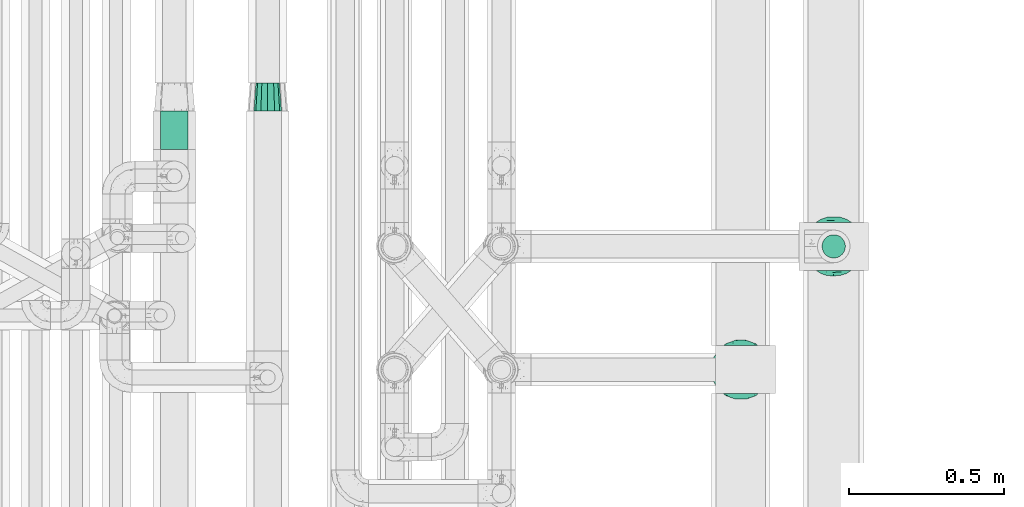
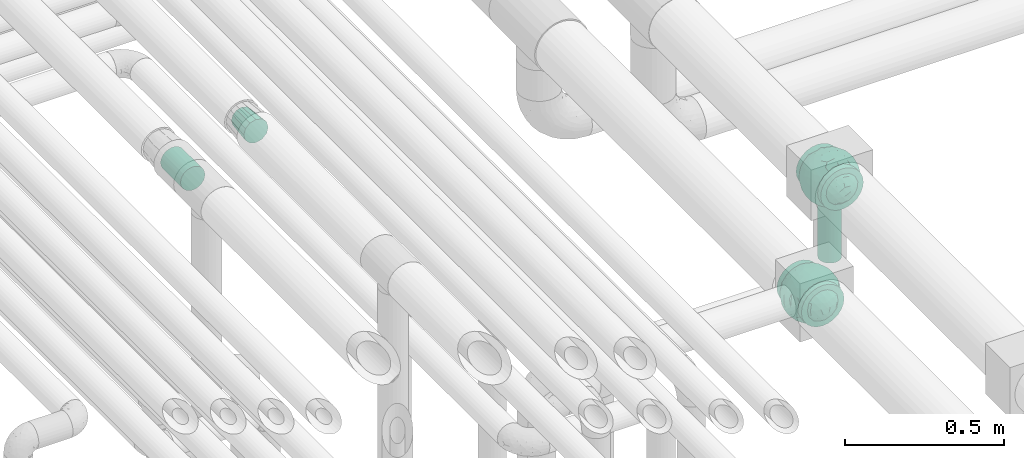
# One storey, part 627 of 827: 3 flow fittings, 2 flow segments.
"""IFC2X3 building model written with IfcOpenShell, lengths in millimetres."""

from ifc_helpers import new_model, entity, si_unit, converted_unit, derived_unit, direction, frame, origin, origin_2d_with_axis, place, context, subcontext, project, spatial, circle, extrude, faceted_brep, source, transform, mapped, material, material_list, type_object, type_shapes, element, save


model = new_model("IFC2X3")

# Units and contexts
model_context = context("Model", 3, precision=0.01, world=origin(), true_north=direction((6.12303176911189e-17, 1.0)))
body_context = subcontext(model_context, "Body", "Model", "MODEL_VIEW")
ifc_project = project(units=[si_unit("LENGTHUNIT", "METRE", prefix="MILLI"), si_unit("AREAUNIT", "SQUARE_METRE"), si_unit("VOLUMEUNIT", "CUBIC_METRE"), converted_unit("PLANEANGLEUNIT", "DEGREE", entity("IfcRatioMeasure", 0.0174532925199433), si_unit("PLANEANGLEUNIT", "RADIAN"), dimensions=[0, 0, 0, 0, 0, 0, 0]), si_unit("MASSUNIT", "GRAM", prefix="KILO"), derived_unit("MASSDENSITYUNIT", [(si_unit("MASSUNIT", "GRAM", prefix="KILO"), 1), (si_unit("LENGTHUNIT", "METRE"), -3)]), derived_unit("MOMENTOFINERTIAUNIT", [(si_unit("LENGTHUNIT", "METRE"), 4)]), si_unit("TIMEUNIT", "SECOND"), si_unit("FREQUENCYUNIT", "HERTZ"), si_unit("THERMODYNAMICTEMPERATUREUNIT", "DEGREE_CELSIUS"), derived_unit("THERMALTRANSMITTANCEUNIT", [(si_unit("MASSUNIT", "GRAM", prefix="KILO"), 1), (si_unit("THERMODYNAMICTEMPERATUREUNIT", "KELVIN"), -1), (si_unit("TIMEUNIT", "SECOND"), -3)]), derived_unit("VOLUMETRICFLOWRATEUNIT", [(si_unit("LENGTHUNIT", "METRE"), 3), (si_unit("TIMEUNIT", "SECOND"), -1)]), derived_unit("MASSFLOWRATEUNIT", [(si_unit("MASSUNIT", "GRAM", prefix="KILO"), 1), (si_unit("TIMEUNIT", "SECOND"), -1)]), derived_unit("ROTATIONALFREQUENCYUNIT", [(si_unit("TIMEUNIT", "SECOND"), -1)]), si_unit("ELECTRICCURRENTUNIT", "AMPERE"), si_unit("ELECTRICVOLTAGEUNIT", "VOLT"), si_unit("POWERUNIT", "WATT"), si_unit("FORCEUNIT", "NEWTON", prefix="KILO"), si_unit("ILLUMINANCEUNIT", "LUX"), si_unit("LUMINOUSFLUXUNIT", "LUMEN"), si_unit("LUMINOUSINTENSITYUNIT", "CANDELA"), derived_unit("USERDEFINED", [(si_unit("MASSUNIT", "GRAM", prefix="KILO"), -1), (si_unit("LENGTHUNIT", "METRE"), -2), (si_unit("TIMEUNIT", "SECOND"), 3), (si_unit("LUMINOUSFLUXUNIT", "LUMEN"), 1)]), derived_unit("LINEARVELOCITYUNIT", [(si_unit("LENGTHUNIT", "METRE"), 1), (si_unit("TIMEUNIT", "SECOND"), -1)]), si_unit("PRESSUREUNIT", "PASCAL"), derived_unit("USERDEFINED", [(si_unit("LENGTHUNIT", "METRE"), -2), (si_unit("MASSUNIT", "GRAM", prefix="KILO"), 1), (si_unit("TIMEUNIT", "SECOND"), -2)]), derived_unit("LINEARFORCEUNIT", [(si_unit("MASSUNIT", "GRAM", prefix="KILO"), 1), (si_unit("LENGTHUNIT", "METRE"), 1), (si_unit("TIMEUNIT", "SECOND"), -2), (si_unit("LENGTHUNIT", "METRE"), -1)]), derived_unit("PLANARFORCEUNIT", [(si_unit("MASSUNIT", "GRAM", prefix="KILO"), 1), (si_unit("LENGTHUNIT", "METRE"), 1), (si_unit("TIMEUNIT", "SECOND"), -2), (si_unit("LENGTHUNIT", "METRE"), -2)])], contexts=[model_context])

# Site, building, storey
site_placement = place(None, origin())
site = spatial("IfcSite", under=ifc_project, at=site_placement, CompositionType="ELEMENT")
building_placement = place(site_placement, origin())
building = spatial("IfcBuilding", under=site, at=building_placement, CompositionType="ELEMENT")
storey_placement = place(building_placement, frame((0.0, 0.0, 28200.0)))
storey = spatial("IfcBuildingStorey", under=building, at=storey_placement, Name="08", CompositionType="ELEMENT", Elevation=28200.0)

# Flow segments
pipe_segment_type = type_object("IfcPipeSegmentType", PredefinedType="NOTDEFINED")
flow_segment_1_placement = place(storey_placement, frame((38008.95, 12940.3, 2695.0)))
element("IfcFlowSegment", 1, at=flow_segment_1_placement, inside=storey, type_object=pipe_segment_type, context=body_context, shape_type="SweptSolid", body=[
    extrude(circle(Radius=37.75, at=origin_2d_with_axis()), frame((39.35, 39.35, 0.0)), (0.0, 0.0, 1.0), 222.500000000001),
])
flow_segment_2_placement = place(storey_placement, frame((35872.22, 13292.08, 3504.16)))
element("IfcFlowSegment", 2, at=flow_segment_2_placement, inside=storey, type_object=pipe_segment_type, context=body_context, shape_type="SweptSolid", body=[
    extrude(circle(Radius=44.25, at=origin_2d_with_axis()), frame((45.85, 0.0, 45.85), z_axis=(0.0, 1.0, 0.0), x_axis=(-1.0, 0.0, 0.0)), (0.0, 0.0, 1.0), 125.619330449334),
])

# Flow fittings
ifc_material_1 = material()
ifc_material_2 = material(Name="ADSK_")
ifc_material_list = material_list([ifc_material_1, ifc_material_2])
pipe_fitting_type_1 = type_object("IfcPipeFittingType", Name="ADSK_1", PredefinedType="NOTDEFINED", material=ifc_material_list)
shared_shape_1 = source(origin(), body_context, "Body", "Brep", [
    faceted_brep([(-77.5, 38.75, -67.12), (-77.5, 20.06, -74.86), (-77.5, 0.0, -77.5), (-77.5, -20.06, -74.86), (-77.5, -38.75, -67.12), (-77.5, -54.8, -54.8), (-77.5, -67.12, -38.75), (-77.5, -74.86, -20.06), (-77.5, -76.18, -10.03), (-77.5, -77.5, 0.0), (-77.5, -76.18, 10.03), (-77.5, -74.86, 20.06), (-77.5, -67.12, 38.75), (-77.5, -54.8, 54.8), (-77.5, -38.75, 67.12), (-77.5, -20.06, 74.86), (-77.5, 0.0, 77.5), (-77.5, 20.06, 74.86), (-77.5, 38.75, 67.12), (-77.5, 54.8, 54.8), (-77.5, 67.12, 38.75), (-77.5, 74.86, 20.06), (-77.5, 77.5, 0.0), (-77.5, 74.86, -20.06), (-77.5, 67.12, -38.75), (-77.5, 54.8, -54.8), (77.5, 0.0, -77.5), (77.5, 20.06, -74.86), (77.5, 38.75, -67.12), (77.5, 54.8, -54.8), (77.5, 67.12, -38.75), (77.5, 74.86, -20.06), (77.5, 77.5, 0.0), (77.5, 74.86, 20.06), (77.5, 67.12, 38.75), (77.5, 54.8, 54.8), (77.5, 38.75, 67.12), (77.5, 20.06, 74.86), (77.5, 0.0, 77.5), (77.5, -20.06, 74.86), (77.5, -38.75, 67.12), (77.5, -54.8, 54.8), (77.5, -67.12, 38.75), (77.5, -74.86, 20.06), (77.5, -76.18, 10.03), (77.5, -77.5, 0.0), (77.5, -76.18, -10.03), (77.5, -74.86, -20.06), (77.5, -67.12, -38.75), (77.5, -54.8, -54.8), (77.5, -38.75, -67.12), (77.5, -20.06, -74.86), (32.85, -76.55, 12.09), (35.0, -77.5, 0.0), (-35.0, -77.5, 0.0), (26.77, -74.15, 22.55), (6.15, -69.42, 34.46), (17.58, -71.35, 30.26), (11.87, -70.38, 32.36), (-32.85, -76.55, 12.09), (-33.92, -77.03, 6.04), (-26.78, -74.15, 22.54), (-17.59, -71.35, 30.26), (-11.87, -70.38, 32.36), (-6.16, -69.42, 34.45), (0.0, -69.42, 34.45), (33.92, -77.03, 6.04), (6.15, -69.42, -34.46), (-32.85, -76.55, -12.09), (-33.92, -77.03, -6.04), (17.58, -71.35, -30.26), (11.87, -70.38, -32.36), (32.85, -76.55, -12.09), (26.77, -74.15, -22.55), (33.92, -77.03, -6.04), (-6.16, -69.42, -34.45), (-11.87, -70.38, -32.36), (-17.59, -71.35, -30.26), (0.0, -69.42, -34.45), (-26.78, -74.15, -22.54), (0.0, -82.5, -35.0), (9.06, -82.5, -33.81), (17.5, -82.5, -30.31), (24.75, -82.5, -24.75), (30.31, -82.5, -17.5), (33.81, -82.5, -9.06), (35.0, -82.5, 0.0), (33.81, -82.5, 9.06), (30.31, -82.5, 17.5), (24.75, -82.5, 24.75), (17.5, -82.5, 30.31), (9.06, -82.5, 33.81), (0.0, -82.5, 35.0), (-9.06, -82.5, 33.81), (-17.5, -82.5, 30.31), (-24.75, -82.5, 24.75), (-30.31, -82.5, 17.5), (-33.81, -82.5, 9.06), (-35.0, -82.5, 0.0), (-33.81, -82.5, -9.06), (-30.31, -82.5, -17.5), (-24.75, -82.5, -24.75), (-17.5, -82.5, -30.31), (-9.06, -82.5, -33.81)], [[[0, 1, 2, 3, 4, 5, 6, 7, 8, 9, 10, 11, 12, 13, 14, 15, 16, 17, 18, 19, 20, 21, 22, 23, 24, 25]], [[26, 27, 28, 29, 30, 31, 32, 33, 34, 35, 36, 37, 38, 39, 40, 41, 42, 43, 44, 45, 46, 47, 48, 49, 50, 51]], [[44, 43, 52]], [[53, 45, 44]], [[9, 54, 10]], [[43, 55, 52]], [[42, 41, 56]], [[55, 43, 57]], [[42, 56, 58, 57]], [[41, 13, 56]], [[57, 43, 42]], [[59, 11, 10]], [[10, 54, 60, 59]], [[59, 61, 11]], [[12, 62, 63, 64]], [[12, 11, 62]], [[12, 64, 13]], [[62, 11, 61]], [[13, 64, 65, 56]], [[44, 52, 66, 53]], [[41, 40, 14, 13]], [[16, 15, 39, 38]], [[15, 14, 40, 39]], [[17, 16, 38, 37]], [[34, 33, 21, 20]], [[19, 18, 36, 35]], [[20, 19, 35, 34]], [[37, 36, 18, 17]], [[22, 21, 33, 32]], [[24, 23, 31, 30]], [[23, 22, 32, 31]], [[25, 24, 30, 29]], [[26, 51, 3, 2]], [[1, 0, 28, 27]], [[2, 1, 27, 26]], [[29, 28, 0, 25]], [[4, 3, 51, 50]], [[50, 49, 5, 4]], [[49, 48, 67]], [[8, 68, 69, 54]], [[48, 70, 71, 67]], [[48, 47, 70]], [[49, 67, 5]], [[45, 53, 46]], [[8, 54, 9]], [[72, 73, 47]], [[46, 53, 74, 72]], [[47, 73, 70]], [[6, 75, 76, 77]], [[72, 47, 46]], [[6, 5, 75]], [[77, 7, 6]], [[5, 67, 78, 75]], [[79, 68, 7]], [[68, 8, 7]], [[79, 7, 77]], [[80, 81, 82, 83, 84, 85, 86, 87, 88, 89, 90, 91, 92, 93, 94, 95, 96, 97, 98, 99, 100, 101, 102, 103]], [[98, 97, 60]], [[61, 96, 95]], [[97, 96, 59]], [[95, 94, 62]], [[86, 66, 87]], [[98, 60, 54]], [[59, 96, 61]], [[93, 64, 63]], [[63, 62, 94]], [[62, 61, 95]], [[92, 56, 65, 64]], [[93, 63, 94]], [[58, 56, 91]], [[56, 92, 91]], [[92, 64, 93]], [[55, 89, 88]], [[90, 89, 57]], [[52, 88, 87]], [[90, 58, 91]], [[89, 55, 57]], [[58, 90, 57]], [[87, 66, 52]], [[52, 55, 88]], [[97, 59, 60]], [[66, 86, 53]], [[86, 85, 74]], [[73, 84, 83]], [[85, 84, 72]], [[83, 82, 70]], [[98, 69, 99]], [[86, 74, 53]], [[72, 84, 73]], [[81, 67, 71]], [[71, 70, 82]], [[70, 73, 83]], [[80, 75, 78, 67]], [[81, 71, 82]], [[76, 75, 103]], [[75, 80, 103]], [[80, 67, 81]], [[79, 101, 100]], [[101, 77, 102]], [[100, 99, 68]], [[102, 76, 103]], [[101, 79, 77]], [[76, 102, 77]], [[99, 69, 68]], [[68, 79, 100]], [[85, 72, 74]], [[69, 98, 54]]]),
    faceted_brep([(74.09, -36.62, -50.54), (86.5, -25.35, -35.5), (82.61, -45.18, -22.81), (-16.75, -33.7, -89.27), (0.0, -42.78, -86.92), (-23.87, -49.97, -79.49), (73.94, -14.61, -60.86), (53.84, -28.63, -75.28), (-16.57, 93.95, 0.0), (-18.09, 86.11, -40.53), (-32.84, 86.73, -28.0), (-44.04, -10.15, -85.69), (-19.2, 4.88, -94.83), (-22.92, -15.62, -92.82), (89.65, 32.63, 0.0), (82.61, 44.34, -24.37), (83.9, 48.44, 0.0), (47.7, -82.62, 0.0), (60.26, -69.94, -29.38), (62.27, -74.21, 0.0), (95.4, 0.0, 0.0), (95.4, -16.82, 0.0), (94.13, -8.44, -21.26), (93.14, 13.95, -22.71), (95.4, 16.82, 0.0), (76.54, 8.21, -58.81), (74.09, 36.62, -50.54), (84.96, 22.7, -40.64), (28.25, -36.42, -85.21), (19.67, -61.78, -71.98), (-67.45, 51.53, -46.69), (-45.73, 54.97, -65.36), (-59.68, 42.12, -63.64), (47.7, 82.62, 0.0), (62.27, 74.21, 0.0), (59.48, 63.11, -43.18), (-48.12, -74.69, -38.62), (-33.13, -91.03, 0.0), (-47.7, -82.62, 0.0), (72.35, 57.3, -29.46), (60.01, 43.15, -62.62), (62.52, -52.48, -52.18), (45.73, -54.97, -65.36), (-62.27, -74.21, 0.0), (-73.08, -61.32, 0.0), (-72.41, -59.62, -24.21), (7.26, -81.07, -52.53), (35.35, -68.17, -59.06), (27.87, -86.63, -33.22), (-74.09, -36.62, -50.54), (-84.35, -21.79, -42.37), (-76.59, -6.33, -58.98), (61.55, 0.0, -74.81), (-61.55, 0.0, -74.81), (-79.37, 15.54, -53.33), (-95.4, -16.82, 0.0), (-92.58, -16.52, -23.25), (-89.65, -32.63, 0.0), (63.81, 22.67, -69.28), (-18.69, 68.07, -66.35), (-42.94, 76.94, -40.26), (-74.09, 36.62, -50.54), (-43.64, 36.19, -78.55), (-65.1, 21.71, -68.38), (44.46, 15.06, -84.74), (-65.04, -21.76, -68.42), (-94.63, 4.93, -20.13), (-87.93, 0.0, -40.67), (-89.65, 32.63, 0.0), (-89.27, 26.35, -26.85), (27.96, 84.78, -37.61), (7.26, 81.07, -52.53), (1.19, 92.73, -28.0), (3.41, -92.84, -27.46), (-8.28, -95.41, 0.0), (-11.9, -93.14, -23.83), (73.08, 61.32, 0.0), (87.93, 0.0, -40.67), (73.08, -61.32, 0.0), (83.9, -48.44, 0.0), (-73.08, 61.32, 0.0), (-82.24, 45.34, -23.77), (-83.9, 48.44, 0.0), (-63.57, -59.47, -42.5), (-45.73, -54.97, -65.36), (-82.58, -43.28, -26.32), (29.11, 48.1, -78.89), (45.73, 54.97, -65.36), (44.58, 36.0, -78.11), (-61.2, 65.56, -36.61), (-6.93, -65.5, -71.03), (30.56, -5.14, -91.79), (9.54, -19.86, -94.34), (0.0, 12.89, -96.01), (47.81, -10.83, -83.56), (89.65, -32.63, 0.0), (44.95, 76.64, -38.61), (33.13, 91.03, 0.0), (28.53, 69.09, -61.62), (-51.45, 14.65, -80.76), (22.17, 26.71, -90.44), (33.13, -91.03, 0.0), (44.95, -76.64, -38.61), (72.35, -57.3, -29.46), (16.57, -93.95, 0.0), (-15.25, 22.47, -92.99), (2.72, 32.92, -91.07), (8.92, 50.75, -82.03), (9.42, 67.57, -68.78), (16.57, 93.95, 0.0), (-5.45, -87.35, -41.54), (8.28, -95.41, 0.0), (0.0, -96.88, 0.0), (-24.34, -90.45, -24.71), (-25.14, -82.23, -44.62), (-16.57, -93.95, 0.0), (-9.92, -78.26, -56.23), (-30.26, -67.58, -62.46), (-40.87, -32.58, -81.57), (-34.66, 17.97, -88.66), (-59.69, -42.16, -63.59), (-16.8, 39.61, -86.8), (-28.19, 53.95, -75.36), (-10.32, 55.25, -78.9), (-57.91, -73.21, -25.92), (-83.9, -48.44, 0.0), (-95.4, 0.0, 0.0), (-95.4, 16.82, 0.0), (-72.43, 58.81, -26.08), (-62.27, 74.21, 0.0), (-47.7, 82.62, 0.0), (-33.13, 91.03, 0.0), (0.0, 96.87, 0.0), (-74.09, -36.62, 50.54), (-86.5, -25.35, 35.5), (-82.61, -45.18, 22.81), (16.75, -33.7, 89.27), (0.0, -42.78, 86.92), (23.87, -49.97, 79.49), (-73.94, -14.61, 60.86), (-53.84, -28.63, 75.28), (18.09, 86.11, 40.53), (32.84, 86.73, 28.0), (44.04, -10.15, 85.69), (19.2, 4.88, 94.83), (22.92, -15.62, 92.82), (-82.61, 44.34, 24.37), (-60.26, -69.94, 29.38), (-94.13, -8.44, 21.26), (-93.14, 13.95, 22.71), (-76.54, 8.21, 58.81), (-74.09, 36.62, 50.54), (-84.96, 22.7, 40.64), (-28.25, -36.42, 85.21), (-19.67, -61.78, 71.98), (67.45, 51.53, 46.69), (45.73, 54.97, 65.36), (59.68, 42.12, 63.64), (-28.53, 69.09, 61.62), (-45.73, 54.97, 65.36), (-29.11, 48.1, 78.89), (48.12, -74.69, 38.62), (-59.48, 63.11, 43.18), (-72.35, 57.3, 29.46), (-60.01, 43.15, 62.62), (-35.35, -68.17, 59.06), (-7.26, -81.07, 52.53), (72.41, -59.62, 24.21), (-3.41, -92.84, 27.46), (74.09, -36.62, 50.54), (84.35, -21.79, 42.37), (76.59, -6.33, 58.98), (-61.55, 0.0, 74.81), (61.55, 0.0, 74.81), (79.37, 15.54, 53.33), (92.58, -16.52, 23.25), (-63.81, 22.67, 69.28), (18.69, 68.07, 66.35), (42.94, 76.94, 40.26), (74.09, 36.62, 50.54), (43.64, 36.19, 78.55), (65.1, 21.71, 68.38), (-44.46, 15.06, 84.74), (65.04, -21.76, 68.42), (94.63, 4.93, 20.13), (87.93, 0.0, 40.67), (89.27, 26.35, 26.85), (-27.96, 84.78, 37.61), (-7.26, 81.07, 52.53), (-1.19, 92.73, 28.0), (11.9, -93.14, 23.83), (-87.93, 0.0, 40.67), (82.24, 45.34, 23.77), (63.57, -59.47, 42.5), (45.73, -54.97, 65.36), (82.58, -43.28, 26.32), (-44.58, 36.0, 78.11), (61.2, 65.56, 36.61), (25.14, -82.23, 44.62), (5.45, -87.35, 41.54), (24.34, -90.45, 24.71), (6.93, -65.5, 71.03), (-30.56, -5.14, 91.79), (-9.54, -19.86, 94.34), (0.0, 12.89, 96.01), (-47.81, -10.83, 83.56), (-44.95, 76.64, 38.61), (51.45, 14.65, 80.76), (-62.52, -52.48, 52.18), (-45.73, -54.97, 65.36), (-22.17, 26.71, 90.44), (-44.95, -76.64, 38.61), (-72.35, -57.3, 29.46), (-27.87, -86.63, 33.22), (15.25, 22.47, 92.99), (-2.72, 32.92, 91.07), (-8.92, 50.75, 82.03), (-9.42, 67.57, 68.78), (9.92, -78.26, 56.23), (30.26, -67.58, 62.46), (40.87, -32.58, 81.57), (34.66, 17.97, 88.66), (59.69, -42.16, 63.59), (16.8, 39.61, 86.8), (28.19, 53.95, 75.36), (10.32, 55.25, 78.9), (57.91, -73.21, 25.92), (72.43, 58.81, 26.08)], [[[0, 1, 2]], [[3, 4, 5]], [[6, 0, 7]], [[8, 9, 10]], [[11, 12, 13]], [[14, 15, 16]], [[17, 18, 19]], [[20, 21, 22]], [[23, 24, 20]], [[25, 26, 27]], [[4, 28, 29]], [[30, 31, 32]], [[33, 34, 35]], [[36, 37, 38]], [[35, 39, 40]], [[41, 18, 42]], [[43, 44, 45]], [[46, 47, 48]], [[49, 50, 51]], [[52, 25, 6]], [[53, 51, 54]], [[55, 56, 57]], [[26, 25, 58]], [[59, 31, 60]], [[32, 61, 30]], [[62, 63, 32]], [[52, 64, 58]], [[51, 65, 49]], [[56, 66, 67]], [[66, 68, 69]], [[70, 71, 72]], [[73, 74, 75]], [[6, 7, 52]], [[20, 22, 23]], [[76, 39, 34]], [[15, 26, 39]], [[1, 77, 22]], [[78, 2, 79]], [[61, 54, 69]], [[80, 81, 82]], [[36, 83, 84]], [[85, 56, 50]], [[86, 87, 88]], [[60, 31, 89]], [[48, 73, 46]], [[4, 29, 90]], [[91, 92, 93]], [[7, 94, 52]], [[77, 23, 22]], [[95, 79, 2]], [[0, 6, 1]], [[1, 22, 95]], [[1, 95, 2]], [[27, 23, 77]], [[15, 14, 23]], [[25, 27, 77]], [[15, 76, 16]], [[40, 39, 26]], [[39, 76, 15]], [[96, 97, 33]], [[70, 98, 71]], [[39, 35, 34]], [[87, 86, 98]], [[77, 1, 6]], [[25, 52, 58]], [[62, 99, 63]], [[26, 15, 27]], [[6, 25, 77]], [[0, 41, 7]], [[42, 28, 7]], [[92, 91, 28]], [[94, 28, 91]], [[88, 87, 40]], [[52, 94, 64]], [[40, 26, 58]], [[100, 91, 93]], [[88, 40, 58]], [[22, 21, 95]], [[101, 102, 17]], [[103, 78, 19]], [[41, 0, 103]], [[18, 102, 42]], [[101, 48, 102]], [[101, 104, 48]], [[29, 28, 42]], [[28, 4, 92]], [[102, 47, 42]], [[90, 29, 46]], [[88, 58, 64]], [[40, 87, 35]], [[87, 96, 35]], [[33, 35, 96]], [[100, 64, 91]], [[88, 64, 100]], [[12, 105, 93]], [[98, 96, 87]], [[106, 100, 93]], [[86, 100, 107]], [[100, 86, 88]], [[98, 108, 71]], [[108, 86, 107]], [[109, 70, 72]], [[70, 109, 97]], [[96, 98, 70]], [[97, 96, 70]], [[78, 103, 2]], [[0, 2, 103]], [[41, 103, 18]], [[7, 41, 42]], [[19, 18, 103]], [[102, 18, 17]], [[75, 110, 73]], [[73, 104, 111, 112]], [[113, 114, 110]], [[115, 75, 74]], [[36, 114, 37]], [[90, 5, 4]], [[73, 48, 104]], [[47, 46, 29]], [[46, 116, 90]], [[5, 117, 84]], [[90, 116, 117]], [[118, 13, 3]], [[118, 5, 84]], [[11, 119, 12]], [[65, 120, 49]], [[11, 13, 118]], [[63, 53, 54]], [[121, 122, 123]], [[90, 117, 5]], [[49, 120, 83]], [[117, 36, 84]], [[36, 117, 114]], [[43, 45, 124]], [[38, 124, 36]], [[83, 124, 45]], [[85, 125, 57]], [[125, 85, 44]], [[45, 49, 83]], [[66, 55, 126, 127]], [[57, 56, 85]], [[56, 67, 50]], [[51, 50, 67]], [[85, 50, 49]], [[54, 51, 67]], [[51, 53, 65]], [[69, 54, 67]], [[54, 61, 63]], [[69, 67, 66]], [[128, 129, 89]], [[11, 65, 53]], [[120, 118, 84]], [[32, 63, 61]], [[99, 53, 63]], [[118, 120, 65]], [[83, 120, 84]], [[129, 128, 80]], [[62, 32, 31]], [[60, 130, 131]], [[130, 60, 89]], [[9, 71, 59]], [[10, 60, 131]], [[108, 59, 71]], [[71, 9, 72]], [[62, 121, 119]], [[122, 59, 123]], [[62, 119, 99]], [[62, 31, 122]], [[106, 107, 100]], [[44, 85, 45]], [[49, 45, 85]], [[55, 66, 56]], [[62, 122, 121]], [[89, 129, 130]], [[65, 11, 118]], [[11, 53, 99]], [[80, 128, 81]], [[30, 128, 89]], [[81, 61, 69]], [[61, 81, 128]], [[82, 81, 69]], [[10, 59, 60]], [[72, 8, 132]], [[8, 72, 9]], [[109, 72, 132]], [[3, 92, 4]], [[92, 13, 12]], [[23, 27, 15]], [[14, 24, 23]], [[11, 99, 119]], [[128, 30, 61]], [[31, 30, 89]], [[28, 94, 7]], [[64, 94, 91]], [[48, 47, 102]], [[29, 42, 47]], [[105, 106, 93]], [[123, 106, 121]], [[86, 108, 98]], [[108, 107, 123]], [[73, 112, 74]], [[113, 75, 115]], [[114, 116, 110]], [[115, 37, 113]], [[37, 114, 113]], [[46, 73, 110]], [[117, 116, 114]], [[110, 75, 113]], [[46, 110, 116]], [[118, 3, 5]], [[92, 3, 13]], [[105, 119, 121]], [[92, 12, 93]], [[119, 105, 12]], [[106, 105, 121]], [[43, 124, 38]], [[83, 36, 124]], [[68, 66, 127]], [[68, 82, 69]], [[31, 59, 122]], [[108, 123, 59]], [[106, 123, 107]], [[8, 10, 131]], [[59, 10, 9]], [[133, 134, 135]], [[136, 137, 138]], [[139, 133, 140]], [[109, 141, 142]], [[143, 144, 145]], [[68, 146, 82]], [[38, 147, 43]], [[148, 126, 55]], [[149, 127, 126]], [[150, 151, 152]], [[137, 153, 154]], [[155, 156, 157]], [[158, 159, 160]], [[161, 101, 17]], [[162, 163, 164]], [[154, 165, 166]], [[19, 78, 167]], [[168, 115, 74, 112]], [[169, 170, 171]], [[172, 150, 139]], [[173, 171, 174]], [[21, 175, 95]], [[151, 150, 176]], [[177, 156, 178]], [[157, 179, 155]], [[180, 181, 157]], [[172, 182, 176]], [[171, 183, 169]], [[175, 184, 185]], [[186, 24, 14, 16]], [[187, 188, 189]], [[168, 111, 190]], [[139, 140, 172]], [[126, 148, 149]], [[80, 163, 129]], [[146, 151, 163]], [[134, 191, 148]], [[44, 135, 125]], [[179, 174, 186]], [[76, 192, 16]], [[161, 193, 194]], [[195, 175, 170]], [[160, 159, 196]], [[178, 156, 197]], [[198, 199, 200]], [[137, 154, 201]], [[202, 203, 204]], [[140, 205, 172]], [[134, 133, 139]], [[125, 135, 57]], [[148, 191, 149]], [[134, 148, 57]], [[134, 57, 135]], [[152, 149, 191]], [[146, 68, 149]], [[150, 152, 191]], [[146, 80, 82]], [[164, 163, 151]], [[163, 80, 146]], [[162, 130, 129]], [[130, 206, 131]], [[163, 162, 129]], [[158, 188, 187]], [[191, 134, 139]], [[150, 172, 176]], [[180, 207, 181]], [[151, 146, 152]], [[139, 150, 191]], [[133, 208, 140]], [[209, 153, 140]], [[203, 202, 153]], [[205, 153, 202]], [[196, 159, 164]], [[172, 205, 182]], [[164, 151, 176]], [[210, 202, 204]], [[196, 164, 176]], [[148, 55, 57]], [[38, 37, 211]], [[212, 44, 43]], [[208, 133, 212]], [[147, 211, 209]], [[165, 213, 166]], [[209, 208, 147]], [[154, 153, 209]], [[153, 137, 203]], [[211, 165, 209]], [[201, 154, 166]], [[196, 176, 182]], [[164, 159, 162]], [[159, 206, 162]], [[130, 162, 206]], [[210, 182, 202]], [[196, 182, 210]], [[144, 214, 204]], [[158, 206, 159]], [[215, 210, 204]], [[160, 210, 216]], [[210, 160, 196]], [[158, 217, 188]], [[217, 160, 216]], [[8, 187, 189]], [[187, 8, 131]], [[206, 158, 187]], [[131, 206, 187]], [[44, 212, 135]], [[133, 135, 212]], [[208, 212, 147]], [[140, 208, 209]], [[43, 147, 212]], [[211, 147, 38]], [[199, 168, 190]], [[213, 115, 168]], [[213, 168, 166]], [[104, 190, 111]], [[161, 198, 101]], [[201, 138, 137]], [[37, 115, 213]], [[211, 37, 213]], [[166, 218, 201]], [[138, 219, 194]], [[201, 218, 219]], [[220, 145, 136]], [[220, 138, 194]], [[143, 221, 144]], [[183, 222, 169]], [[143, 145, 220]], [[181, 173, 174]], [[223, 224, 225]], [[201, 219, 138]], [[169, 222, 193]], [[219, 161, 194]], [[161, 219, 198]], [[19, 167, 226]], [[17, 226, 161]], [[193, 226, 167]], [[195, 79, 95]], [[79, 195, 78]], [[167, 169, 193]], [[184, 21, 20, 24]], [[95, 175, 195]], [[175, 185, 170]], [[171, 170, 185]], [[195, 170, 169]], [[174, 171, 185]], [[171, 173, 183]], [[186, 174, 185]], [[174, 179, 181]], [[186, 185, 184]], [[227, 34, 197]], [[143, 183, 173]], [[222, 220, 194]], [[157, 181, 179]], [[207, 173, 181]], [[220, 222, 183]], [[193, 222, 194]], [[34, 227, 76]], [[180, 157, 156]], [[178, 33, 97]], [[33, 178, 197]], [[141, 188, 177]], [[142, 178, 97]], [[217, 177, 188]], [[188, 141, 189]], [[180, 223, 221]], [[224, 177, 225]], [[180, 221, 207]], [[180, 156, 224]], [[215, 216, 210]], [[78, 195, 167]], [[169, 167, 195]], [[21, 184, 175]], [[186, 184, 24]], [[197, 34, 33]], [[183, 143, 220]], [[143, 173, 207]], [[76, 227, 192]], [[155, 227, 197]], [[192, 179, 186]], [[179, 192, 227]], [[16, 192, 186]], [[142, 177, 178]], [[189, 109, 132]], [[109, 189, 141]], [[8, 189, 132]], [[136, 203, 137]], [[203, 145, 144]], [[149, 152, 146]], [[68, 127, 149]], [[143, 207, 221]], [[227, 155, 179]], [[156, 155, 197]], [[153, 205, 140]], [[182, 205, 202]], [[213, 165, 211]], [[154, 209, 165]], [[214, 215, 204]], [[225, 215, 223]], [[160, 217, 158]], [[217, 216, 225]], [[168, 112, 111]], [[200, 190, 104]], [[198, 218, 199]], [[104, 101, 200]], [[101, 198, 200]], [[166, 168, 199]], [[219, 218, 198]], [[199, 190, 200]], [[166, 199, 218]], [[220, 136, 138]], [[203, 136, 145]], [[214, 221, 223]], [[203, 144, 204]], [[221, 214, 144]], [[215, 214, 223]], [[19, 226, 17]], [[193, 161, 226]], [[180, 224, 223]], [[156, 177, 224]], [[217, 225, 177]], [[215, 225, 216]], [[109, 142, 97]], [[177, 142, 141]]]),
])
type_shapes(pipe_fitting_type_1, [shared_shape_1])
for number, where, z_axis, x_axis, name in (
    (3, (38048.3, 12979.64, 3000.0), (1.0, 0.0, 0.0), (0.0, 1.0, 0.0), "ADSK_1"),
    (4, (37748.3, 12581.17, 2899.91), (0.0, 7.18992411717632e-07, 1.0), (0.0, -1.0, 7.18992411717632e-07), "ADSK_1"),
):
    element("IfcFlowFitting", number, at=place(storey_placement, frame(where, z_axis=z_axis, x_axis=x_axis)), inside=storey, type_object=pipe_fitting_type_1, material=ifc_material_list, Name=name, ObjectType="ADSK_1", context=body_context, shape_type="MappedRepresentation", body=[
        mapped(shared_shape_1, transform((0.0, 0.0, 0.0), scale=1.0)),
    ])
pipe_fitting_type_2 = type_object("IfcPipeFittingType", Name="ADSK_1", PredefinedType="NOTDEFINED", material=ifc_material_1)
shared_shape_2 = source(origin(), body_context, "Body", "Brep", [
    faceted_brep([(89.0, -44.45, 0.0), (89.0, -41.96, -9.31), (89.0, -38.49, -22.22), (89.0, -30.36, -30.36), (89.0, -22.23, -38.49), (89.0, -11.11, -41.47), (89.0, 0.0, -44.45), (89.0, 11.11, -41.47), (89.0, 22.22, -38.49), (89.0, 30.36, -30.36), (89.0, 38.49, -22.22), (89.0, 41.96, -9.31), (89.0, 44.45, 0.0), (89.0, 41.96, 9.31), (89.0, 38.49, 22.23), (89.0, 30.36, 30.36), (89.0, 22.22, 38.49), (89.0, 11.11, 41.47), (89.0, 0.0, 44.45), (89.0, -11.11, 41.47), (89.0, -22.23, 38.49), (89.0, -30.36, 30.36), (89.0, -38.49, 22.23), (89.0, -41.96, 9.31), (0.0, 38.05, 0.0), (0.0, 35.5, -9.51), (0.0, 32.95, -19.02), (0.0, 25.99, -25.99), (0.0, 19.02, -32.95), (0.0, 9.51, -35.5), (0.0, 0.0, -38.05), (0.0, -9.51, -35.5), (0.0, -19.03, -32.95), (0.0, -25.99, -25.99), (0.0, -32.95, -19.02), (0.0, -35.5, -9.51), (0.0, -38.05, 0.0), (0.0, -35.5, 9.51), (0.0, -32.95, 19.03), (0.0, -25.99, 25.99), (0.0, -19.03, 32.95), (0.0, -9.51, 35.5), (0.0, 0.0, 38.05), (0.0, 9.51, 35.5), (0.0, 19.03, 32.95), (0.0, 25.99, 25.99), (0.0, 32.95, 19.03), (0.0, 35.5, 9.51)], [[[0, 1, 2, 3, 4, 5, 6, 7, 8, 9, 10, 11, 12, 13, 14, 15, 16, 17, 18, 19, 20, 21, 22, 23]], [[24, 25, 26, 27, 28, 29, 30, 31, 32, 33, 34, 35, 36, 37, 38, 39, 40, 41, 42, 43, 44, 45, 46, 47]], [[2, 1, 0, 36, 35, 34]], [[28, 8, 7, 6, 30, 29]], [[32, 4, 3, 2, 34, 33]], [[5, 4, 32, 31, 30, 6]], [[10, 26, 25, 24, 12, 11]], [[9, 8, 28, 27, 26, 10]], [[14, 13, 12, 24, 47, 46]], [[40, 20, 19, 18, 42, 41]], [[44, 16, 15, 14, 46, 45]], [[17, 16, 44, 43, 42, 18]], [[22, 38, 37, 36, 0, 23]], [[21, 20, 40, 39, 38, 22]]]),
])
type_shapes(pipe_fitting_type_2, [shared_shape_2])
flow_fitting_placement = place(storey_placement, frame((36220.03, 13506.7, 3550.0), z_axis=(0.0, 2.47198144799298e-06, 1.0), x_axis=(0.0, -1.0, 2.47198144799298e-06)))
element("IfcFlowFitting", 5, at=flow_fitting_placement, inside=storey, type_object=pipe_fitting_type_2, material=ifc_material_1, Name="ADSK_1", ObjectType="ADSK_1", context=body_context, shape_type="MappedRepresentation", body=[
    mapped(shared_shape_2, transform((0.0, 0.0, 0.0), scale=1.0)),
])

save(model, "model.ifc")
